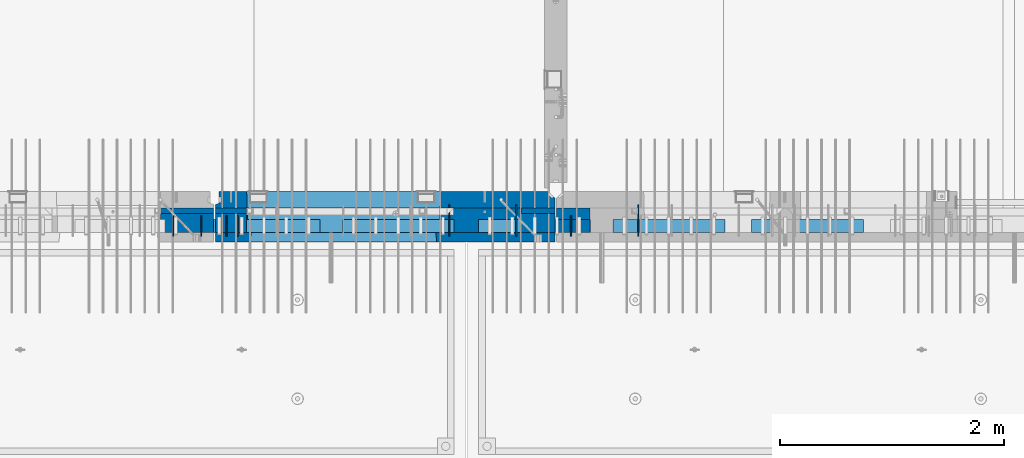
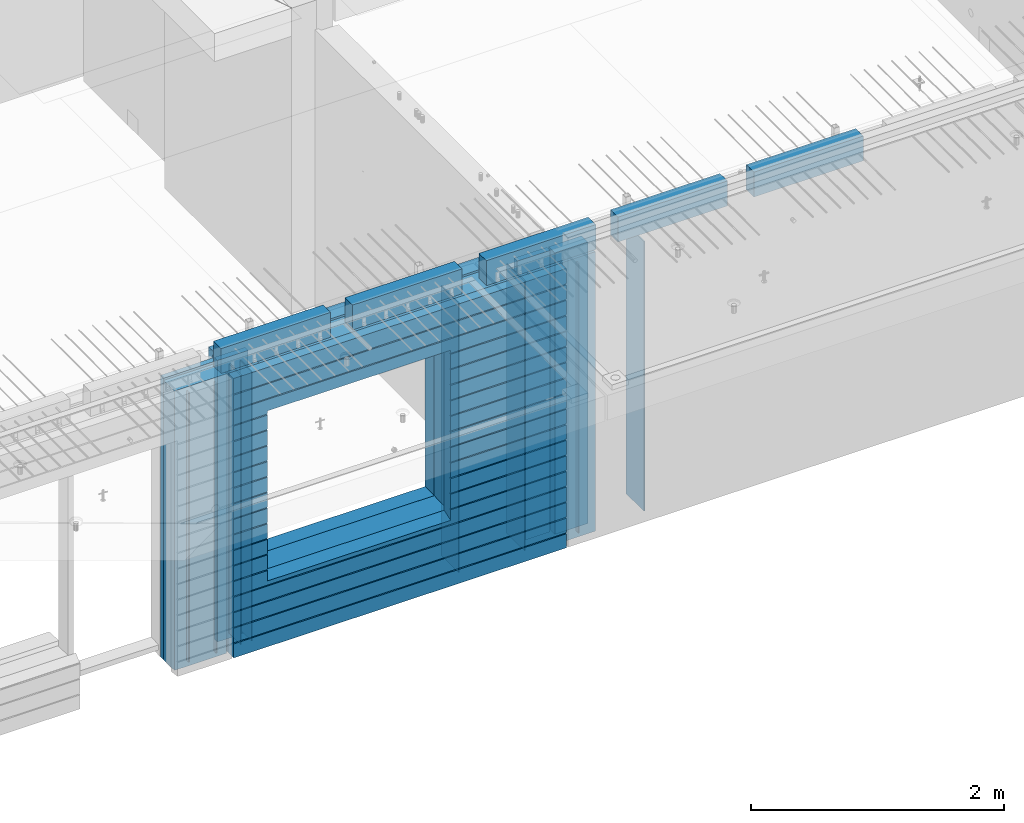
# One storey, part 222 of 334: 24 walls, 10 elements without a shape of their own.
"""IFC2X3 building model written with IfcOpenShell, lengths in millimetres."""

import ifcopenshell
import ifcopenshell.guid

model = None  # the IFC model being written
_history = None  # IfcOwnerHistory: only IFC2X3 demands one
_inside = {}  # id of a spatial element -> (the spatial element, [elements in it])
_under = {}  # id of a project, library or spatial element -> (it, [spatial elements below it])
_declared = {}  # id of a project -> (the project, [libraries it declares])
_typed = {}  # id of a type object -> (the type object, [elements of that type])
_made_of = {}  # id of a material, layer set ... -> (it, [elements and type objects made of it])


def new_model(schema):
    """Start an empty IFC model of exactly this schema.

    Asked for "IFC4X3", IfcOpenShell would pick the latest addendum, in which some entities
    have other attributes; the version numbers below select the first issue.
    IFC2X3 requires an IfcOwnerHistory on every rooted entity: one is made here for all.
    """
    global model, _history
    if schema == "IFC4X3":
        model = ifcopenshell.file(schema_version=(4, 3, 0, 0))
    else:
        model = ifcopenshell.file(schema=schema)
    _inside.clear()
    _under.clear()
    _declared.clear()
    _typed.clear()
    _made_of.clear()
    _history = None
    if model.schema == "IFC2X3":
        org = make("IfcOrganization", Name="unknown")
        user = make(
            "IfcPersonAndOrganization",
            ThePerson=make("IfcPerson", FamilyName="unknown"),
            TheOrganization=org,
        )
        app = make(
            "IfcApplication",
            ApplicationDeveloper=org,
            Version="unknown",
            ApplicationFullName="unknown",
            ApplicationIdentifier="unknown",
        )
        _history = make(
            "IfcOwnerHistory",
            OwningUser=user,
            OwningApplication=app,
            ChangeAction="ADDED",
            CreationDate=0,
        )
    return model


def make(cls, **values):
    """One entity of the class cls with the attributes given. An attribute that is None is left unset."""
    return model.create_entity(
        cls, **{name: value for name, value in values.items() if value is not None}
    )


def rooted(cls, **values):
    """An entity with a GlobalId (a new one), such as an element, a storey or a relation."""
    return make(cls, GlobalId=ifcopenshell.guid.new(), OwnerHistory=_history, **values)


def si_unit(unit_type, name, prefix=None):
    """IfcSIUnit, for example si_unit("LENGTHUNIT", "METRE", prefix="MILLI")."""
    return make("IfcSIUnit", UnitType=unit_type, Prefix=prefix, Name=name)


def assignment(units):
    """IfcUnitAssignment: the units of a project."""
    return None if units is None else make("IfcUnitAssignment", Units=units)


def point(xyz):
    """IfcCartesianPoint."""
    return None if xyz is None else make("IfcCartesianPoint", Coordinates=xyz)


def direction(xyz):
    """IfcDirection."""
    return None if xyz is None else make("IfcDirection", DirectionRatios=xyz)


def frame(location, z_axis=None, x_axis=None):
    """IfcAxis2Placement3D, a coordinate frame: its origin and axes. An axis left out is left unset."""
    return make(
        "IfcAxis2Placement3D",
        Location=point(location),
        Axis=direction(z_axis),
        RefDirection=direction(x_axis),
    )


def origin_with_axes():
    """The frame at (0, 0, 0) with the z axis (0, 0, 1) and the x axis (1, 0, 0) written out."""
    return frame((0.0, 0.0, 0.0), z_axis=(0.0, 0.0, 1.0), x_axis=(1.0, 0.0, 0.0))


def place(relative_to, where):
    """IfcLocalPlacement: puts the frame where relative to a parent placement (None: the world)."""
    return make(
        "IfcLocalPlacement", PlacementRelTo=relative_to, RelativePlacement=where
    )


def context(
    kind, dimensions, precision=None, world=None, true_north=None, identifier=None
):
    """IfcGeometricRepresentationContext, for example the 3D "Model" context."""
    return make(
        "IfcGeometricRepresentationContext",
        ContextIdentifier=identifier,
        ContextType=kind,
        CoordinateSpaceDimension=dimensions,
        Precision=precision,
        WorldCoordinateSystem=world,
        TrueNorth=true_north,
    )


def subcontext(parent, identifier, kind, view, scale=None):
    """IfcGeometricRepresentationSubContext, for example "Body" below "Model"."""
    return make(
        "IfcGeometricRepresentationSubContext",
        ContextIdentifier=identifier,
        ContextType=kind,
        ParentContext=parent,
        TargetScale=scale,
        TargetView=view,
    )


def project(units=None, contexts=None):
    """IfcProject with its units and contexts."""
    return rooted(
        "IfcProject",
        Name="project",
        RepresentationContexts=contexts,
        UnitsInContext=assignment(units),
    )


def spatial(cls, under=None, at=None, **own):
    """A site, building, storey or space (cls), placed at a placement, below another one or the project."""
    s = rooted(cls, ObjectPlacement=at, **own)
    if under is not None:
        _under.setdefault(under.id(), (under, []))[1].append(s)
    return s


def faces_of(points, faces, orient=None, outer=None):
    """IfcFace entities. A face is a list of loops; a loop is a list of indices into points, from 0.

    orient and outer hold one flag for each loop. By default every Orientation is true, the
    first loop of a face is its IfcFaceOuterBound and the others are IfcFaceBound.
    """
    made = []
    for i, loops in enumerate(faces):
        bounds = []
        for j, loop in enumerate(loops):
            is_outer = j == 0 if outer is None else outer[i][j]
            bounds.append(
                make(
                    "IfcFaceOuterBound" if is_outer else "IfcFaceBound",
                    Bound=make("IfcPolyLoop", Polygon=[points[k] for k in loop]),
                    Orientation=True if orient is None else orient[i][j],
                )
            )
        made.append(make("IfcFace", Bounds=bounds))
    return made


def faceted_brep(points, faces, orient=None, outer=None, voids=None):
    """IfcFacetedBrep: a solid bounded by flat faces; with voids (closed shells), ...WithVoids."""
    shared = [point(p) for p in points]
    hull = make("IfcClosedShell", CfsFaces=faces_of(shared, faces, orient, outer))
    if voids is None:
        return make("IfcFacetedBrep", Outer=hull)
    return make(
        "IfcFacetedBrepWithVoids",
        Outer=hull,
        Voids=[
            make(cls, CfsFaces=faces_of(shared, fs, o, b)) for cls, fs, o, b in voids
        ],
    )


def shape(context_of_items, identifier, shape_type, items):
    """IfcShapeRepresentation: the items that make up one representation, for example the "Body"."""
    return make(
        "IfcShapeRepresentation",
        ContextOfItems=context_of_items,
        RepresentationIdentifier=identifier,
        RepresentationType=shape_type,
        Items=items,
    )


def material(Name=None, Category=None):
    """IfcMaterial."""
    return make("IfcMaterial", Name=Name, Category=Category)


def made_of(thing, what):
    """Note that an element or type object is made of a material, layer set ...; save() writes the relation."""
    if what is not None:
        _made_of.setdefault(what.id(), (what, []))[1].append(thing)
    return thing


def type_object(cls, material=None, **own):
    """A type object (cls), such as IfcWallType, which elements share."""
    return made_of(rooted(cls, **own), material)


def element(
    cls,
    number,
    at=None,
    inside=None,
    cuts=None,
    type_object=None,
    material=None,
    context=None,
    identifier="Body",
    shape_type=None,
    held_by="IfcProductDefinitionShape",
    body=None,
    shapes=None,
    **own,
):
    """One element of the class cls, such as IfcWall. Its Tag is "e" and its number.

    at: its placement. inside: the storey or other place that contains it. cuts: it is an
    opening in that element (IfcRelVoidsElement). A single representation is given by context,
    identifier, shape_type and body (its items); several are given by shapes. held_by: the class
    of the entity that holds the representations. save() writes the other relations.
    """
    e = rooted(cls, Tag="e%d" % number, ObjectPlacement=at, **own)
    if body is not None:
        shapes = [shape(context, identifier, shape_type, body)]
    if shapes is not None:
        e.Representation = make(held_by, Representations=shapes)
    if inside is not None:
        _inside.setdefault(inside.id(), (inside, []))[1].append(e)
    if cuts is not None:
        rooted(
            "IfcRelVoidsElement", RelatingBuildingElement=cuts, RelatedOpeningElement=e
        )
    if type_object is not None:
        _typed.setdefault(type_object.id(), (type_object, []))[1].append(e)
    return made_of(e, material)


def aggregate(whole, parts):
    """IfcRelAggregates: a whole, such as a stair, and the parts it consists of."""
    return rooted("IfcRelAggregates", RelatingObject=whole, RelatedObjects=parts)


def save(model, path):
    """Write the relations noted so far, then the file.

    IfcRelAggregates (storeys below a building ...), IfcRelContainedInSpatialStructure (elements
    in a storey), IfcRelDefinesByType, IfcRelAssociatesMaterial and IfcRelDeclares: one each for
    every whole, place, type object, material and project.
    """
    for whole, parts in _under.values():
        aggregate(whole, parts)
    for where, things in _inside.values():
        rooted(
            "IfcRelContainedInSpatialStructure",
            RelatedElements=things,
            RelatingStructure=where,
        )
    for kind, things in _typed.values():
        rooted("IfcRelDefinesByType", RelatedObjects=things, RelatingType=kind)
    for what, things in _made_of.values():
        rooted("IfcRelAssociatesMaterial", RelatedObjects=things, RelatingMaterial=what)
    for by, libraries in _declared.values():
        rooted("IfcRelDeclares", RelatingContext=by, RelatedDefinitions=libraries)
    model.write(path)


model = new_model("IFC2X3")

# Units and contexts
model_context = context("Model", 3, precision=1e-05, world=origin_with_axes())
body_context = subcontext(model_context, "Body", "Model", "MODEL_VIEW")
ifc_project = project(units=[si_unit("LENGTHUNIT", "METRE", prefix="MILLI"), si_unit("AREAUNIT", "SQUARE_METRE"), si_unit("VOLUMEUNIT", "CUBIC_METRE"), si_unit("MASSUNIT", "GRAM", prefix="KILO"), si_unit("TIMEUNIT", "SECOND"), si_unit("PLANEANGLEUNIT", "RADIAN"), si_unit("SOLIDANGLEUNIT", "STERADIAN"), si_unit("THERMODYNAMICTEMPERATUREUNIT", "DEGREE_CELSIUS"), si_unit("LUMINOUSINTENSITYUNIT", "LUMEN")], contexts=[model_context])

# Site, building, storey
site_placement = place(None, origin_with_axes())
site = spatial("IfcSite", under=ifc_project, at=site_placement, CompositionType="ELEMENT")
building_placement = place(site_placement, origin_with_axes())
building = spatial("IfcBuilding", under=site, at=building_placement, CompositionType="ELEMENT")
storey_placement = place(building_placement, origin_with_axes())
storey = spatial("IfcBuildingStorey", under=building, at=storey_placement, Name="3", CompositionType="ELEMENT", Elevation=0.0)

# Assembly, walls
assembly_1_placement = place(storey_placement, origin_with_axes())
assembly_1 = element("IfcElementAssembly", 1, at=assembly_1_placement, inside=storey, AssemblyPlace="NOTDEFINED", PredefinedType="REINFORCEMENT_UNIT")
ifc_material_1 = material(Name="Undefined")
wall_type_1 = type_object("IfcWallType", PredefinedType="NOTDEFINED")
wall_1_placement = place(assembly_1_placement, frame((25665.0, 7780.0, 89115.0), z_axis=(0.0, 0.0, 1.0), x_axis=(0.0, -1.0, 0.0)))
wall_1 = element("IfcWall", 2, at=wall_1_placement, type_object=wall_type_1, material=ifc_material_1, Name="(PD)", context=body_context, shape_type="Brep", body=[
    faceted_brep([(0.0, 5.0, -1300.0), (0.0, 5.0, 1300.0), (180.0, 5.0, 1300.0), (180.0, 5.0, -1300.0), (0.0, -5.0, 1300.0), (180.0, -5.0, 1300.0), (0.0, -5.0, -1300.0), (180.0, -5.0, -1300.0)], [[[0, 1, 2, 3]], [[1, 4, 5, 2]], [[4, 6, 7, 5]], [[6, 0, 3, 7]], [[5, 7, 3, 2]], [[6, 4, 1, 0]]]),
])
wall_2_placement = place(assembly_1_placement, frame((25765.0, 7780.0, 89115.0), z_axis=(0.0, 0.0, 1.0), x_axis=(0.0, -1.0, 0.0)))
wall_2 = element("IfcWall", 3, at=wall_2_placement, type_object=wall_type_1, material=ifc_material_1, Name="(PD)", context=body_context, shape_type="Brep", body=[
    faceted_brep([(0.0, 5.0, -1300.0), (0.0, 5.0, 1300.0), (180.0, 5.0, 1300.0), (180.0, 5.0, -1300.0), (0.0, -5.0, 1300.0), (180.0, -5.0, 1300.0), (0.0, -5.0, -1300.0), (180.0, -5.0, -1300.0)], [[[0, 1, 2, 3]], [[1, 4, 5, 2]], [[4, 6, 7, 5]], [[6, 0, 3, 7]], [[5, 7, 3, 2]], [[6, 4, 1, 0]]]),
])
wall_3_placement = place(assembly_1_placement, frame((28255.0, 7880.0, 89115.0), z_axis=(0.0, 0.0, 1.0), x_axis=(0.0, -1.0, 0.0)))
wall_3 = element("IfcWall", 4, at=wall_3_placement, type_object=wall_type_1, material=ifc_material_1, Name="(PD)", context=body_context, shape_type="Brep", body=[
    faceted_brep([(0.0, 5.0, -1300.0), (0.0, 5.0, 1300.0), (280.0, 5.0, 1300.0), (280.0, 5.0, -1300.0), (0.0, -5.0, 1300.0), (280.0, -5.0, 1300.0), (0.0, -5.0, -1300.0), (280.0, -5.0, -1300.0)], [[[0, 1, 2, 3]], [[1, 4, 5, 2]], [[4, 6, 7, 5]], [[6, 0, 3, 7]], [[5, 7, 3, 2]], [[6, 4, 1, 0]]]),
])

assembly_2_placement = place(storey_placement, origin_with_axes())
assembly_2 = element("IfcElementAssembly", 5, at=assembly_2_placement, inside=storey, AssemblyPlace="NOTDEFINED", PredefinedType="REINFORCEMENT_UNIT")
wall_4_placement = place(assembly_2_placement, frame((28745.0021834468, 7780.0, 89115.0), z_axis=(0.0, 0.0, 1.0), x_axis=(0.0, -1.0, 0.0)))
wall_4 = element("IfcWall", 6, at=wall_4_placement, type_object=wall_type_1, material=ifc_material_1, Name="(PD)", context=body_context, shape_type="Brep", body=[
    faceted_brep([(0.0, 5.0, -1300.0), (0.0, 5.0, 1300.0), (180.0, 5.0, 1300.0), (180.0, 5.0, -1300.0), (0.0, -5.0, 1300.0), (180.0, -5.0, 1300.0), (0.0, -5.0, -1300.0), (180.0, -5.0, -1300.0)], [[[0, 1, 2, 3]], [[1, 4, 5, 2]], [[4, 6, 7, 5]], [[6, 0, 3, 7]], [[5, 7, 3, 2]], [[6, 4, 1, 0]]]),
])
wall_5_placement = place(assembly_2_placement, frame((29345.0021834468, 7880.0, 89115.0), z_axis=(0.0, 0.0, 1.0), x_axis=(0.0, -1.0, 0.0)))
wall_5 = element("IfcWall", 7, at=wall_5_placement, type_object=wall_type_1, material=ifc_material_1, Name="(PD)", context=body_context, shape_type="Brep", body=[
    faceted_brep([(0.0, 5.0, -1300.0), (0.0, 5.0, 1300.0), (280.0, 5.0, 1300.0), (280.0, 5.0, -1300.0), (0.0, -5.0, 1300.0), (280.0, -5.0, 1300.0), (0.0, -5.0, -1300.0), (280.0, -5.0, -1300.0)], [[[0, 1, 2, 3]], [[1, 4, 5, 2]], [[4, 6, 7, 5]], [[6, 0, 3, 7]], [[5, 7, 3, 2]], [[6, 4, 1, 0]]]),
])

# Wall
wall_6_placement = place(assembly_1_placement, frame((27655.0, 7880.0, 89115.0), z_axis=(0.0, 0.0, 1.0), x_axis=(0.0, -1.0, 0.0)))
wall_6 = element("IfcWall", 8, at=wall_6_placement, type_object=wall_type_1, material=ifc_material_1, Name="(PD)", context=body_context, shape_type="Brep", body=[
    faceted_brep([(0.0, 5.0, -1300.0), (0.0, 5.0, 1300.0), (280.0, 5.0, 1300.0), (280.0, 5.0, -1300.0), (0.0, -5.0, 1300.0), (280.0, -5.0, 1300.0), (0.0, -5.0, -1300.0), (280.0, -5.0, -1300.0)], [[[0, 1, 2, 3]], [[1, 4, 5, 2]], [[4, 6, 7, 5]], [[6, 0, 3, 7]], [[5, 7, 3, 2]], [[6, 4, 1, 0]]]),
])

# Assembly, walls
assembly_3_placement = place(storey_placement, origin_with_axes())
assembly_3 = element("IfcElementAssembly", 9, at=assembly_3_placement, inside=storey, AssemblyPlace="NOTDEFINED", PredefinedType="REINFORCEMENT_UNIT")
wall_7_placement = place(assembly_3_placement, frame((25190.0, 7780.0, 89115.0), z_axis=(0.0, 0.0, 1.0), x_axis=(0.0, -1.0, 0.0)))
wall_7 = element("IfcWall", 10, at=wall_7_placement, type_object=wall_type_1, material=ifc_material_1, Name="(PD)", context=body_context, shape_type="Brep", body=[
    faceted_brep([(0.0, 5.0, -1300.0), (0.0, 5.0, 1300.0), (180.0, 5.0, 1300.0), (180.0, 5.0, -1300.0), (0.0, -5.0, 1300.0), (180.0, -5.0, 1300.0), (0.0, -5.0, -1300.0), (180.0, -5.0, -1300.0)], [[[0, 1, 2, 3]], [[1, 4, 5, 2]], [[4, 6, 7, 5]], [[6, 0, 3, 7]], [[5, 7, 3, 2]], [[6, 4, 1, 0]]]),
])
wall_8_placement = place(assembly_3_placement, frame((25440.0, 7780.0, 89115.0), z_axis=(0.0, 0.0, 1.0), x_axis=(0.0, -1.0, 0.0)))
wall_8 = element("IfcWall", 11, at=wall_8_placement, type_object=wall_type_1, material=ifc_material_1, Name="(PD)", context=body_context, shape_type="Brep", body=[
    faceted_brep([(0.0, 5.0, -1300.0), (0.0, 5.0, 1300.0), (180.0, 5.0, 1300.0), (180.0, 5.0, -1300.0), (0.0, -5.0, 1300.0), (180.0, -5.0, 1300.0), (0.0, -5.0, -1300.0), (180.0, -5.0, -1300.0)], [[[0, 1, 2, 3]], [[1, 4, 5, 2]], [[4, 6, 7, 5]], [[6, 0, 3, 7]], [[5, 7, 3, 2]], [[6, 4, 1, 0]]]),
])

# Assemblies, walls
assembly_4_placement = place(storey_placement, origin_with_axes())
assembly_4 = element("IfcElementAssembly", 12, at=assembly_4_placement, inside=storey, AssemblyPlace="NOTDEFINED", PredefinedType="REINFORCEMENT_UNIT")
assembly_5_placement = place(assembly_4_placement, origin_with_axes())
assembly_5 = element("IfcElementAssembly", 13, at=assembly_5_placement, Name="Steel Assembly", AssemblyPlace="NOTDEFINED", PredefinedType="NOTDEFINED")
ifc_material_2 = material()
wall_type_2 = type_object("IfcWallType", PredefinedType="NOTDEFINED")
wall_9_placement = place(assembly_5_placement, frame((26699.9998568133, 7690.00021946163, 90590.0), z_axis=(0.0, 0.0, 1.0), x_axis=(1.0, 0.0, 0.0)))
wall_9 = element("IfcWall", 14, at=wall_9_placement, type_object=wall_type_2, material=ifc_material_2, context=body_context, shape_type="Brep", body=[
    faceted_brep([(0.0, 60.0, -120.0), (0.0, 60.0, 120.0), (1000.0, 60.0, 120.0), (1000.0, 60.0, -120.0), (0.0, -60.0, 120.0), (1000.0, -60.0, 120.0), (0.0, -60.0, -120.0), (1000.0, -60.0, -120.0)], [[[0, 1, 2, 3]], [[1, 4, 5, 2]], [[4, 6, 7, 5]], [[6, 0, 3, 7]], [[5, 7, 3, 2]], [[6, 4, 1, 0]]]),
])
aggregate(assembly_5, [wall_9])
assembly_6_placement = place(assembly_4_placement, origin_with_axes())
assembly_6 = element("IfcElementAssembly", 15, at=assembly_6_placement, Name="Steel Assembly", AssemblyPlace="NOTDEFINED", PredefinedType="NOTDEFINED")
aggregate(assembly_4, [assembly_6, assembly_5])
wall_10_placement = place(assembly_6_placement, frame((25499.9998568133, 7690.00021946163, 90590.0), z_axis=(0.0, 0.0, 1.0), x_axis=(1.0, 0.0, 0.0)))
wall_10 = element("IfcWall", 16, at=wall_10_placement, type_object=wall_type_2, material=ifc_material_2, context=body_context, shape_type="Brep", body=[
    faceted_brep([(0.0, 60.0, -120.0), (0.0, 60.0, 120.0), (1000.0, 60.0, 120.0), (1000.0, 60.0, -120.0), (0.0, -60.0, 120.0), (1000.0, -60.0, 120.0), (0.0, -60.0, -120.0), (1000.0, -60.0, -120.0)], [[[0, 1, 2, 3]], [[1, 4, 5, 2]], [[4, 6, 7, 5]], [[6, 0, 3, 7]], [[5, 7, 3, 2]], [[6, 4, 1, 0]]]),
])
aggregate(assembly_6, [wall_10])

assembly_7_placement = place(storey_placement, origin_with_axes())
assembly_7 = element("IfcElementAssembly", 17, at=assembly_7_placement, inside=storey, AssemblyPlace="NOTDEFINED", PredefinedType="REINFORCEMENT_UNIT")
assembly_8_placement = place(assembly_7_placement, origin_with_axes())
assembly_8 = element("IfcElementAssembly", 18, at=assembly_8_placement, Name="Steel Assembly", AssemblyPlace="NOTDEFINED", PredefinedType="NOTDEFINED")
wall_11_placement = place(assembly_8_placement, frame((30359.9998568133, 7690.00021946163, 90590.0), z_axis=(0.0, 0.0, 1.0), x_axis=(1.0, 0.0, 0.0)))
wall_11 = element("IfcWall", 19, at=wall_11_placement, type_object=wall_type_2, material=ifc_material_2, context=body_context, shape_type="Brep", body=[
    faceted_brep([(0.0, 60.0, -120.0), (0.0, 60.0, 120.0), (1000.0, 60.0, 120.0), (1000.0, 60.0, -120.0), (0.0, -60.0, 120.0), (1000.0, -60.0, 120.0), (0.0, -60.0, -120.0), (1000.0, -60.0, -120.0)], [[[0, 1, 2, 3]], [[1, 4, 5, 2]], [[4, 6, 7, 5]], [[6, 0, 3, 7]], [[5, 7, 3, 2]], [[6, 4, 1, 0]]]),
])
aggregate(assembly_8, [wall_11])
assembly_9_placement = place(assembly_7_placement, origin_with_axes())
assembly_9 = element("IfcElementAssembly", 20, at=assembly_9_placement, Name="Steel Assembly", AssemblyPlace="NOTDEFINED", PredefinedType="NOTDEFINED")
wall_12_placement = place(assembly_9_placement, frame((29119.9998568133, 7690.00021946163, 90590.0), z_axis=(0.0, 0.0, 1.0), x_axis=(1.0, 0.0, 0.0)))
wall_12 = element("IfcWall", 21, at=wall_12_placement, type_object=wall_type_2, material=ifc_material_2, context=body_context, shape_type="Brep", body=[
    faceted_brep([(0.0, 60.0, -120.0), (0.0, 60.0, 120.0), (1000.0, 60.0, 120.0), (1000.0, 60.0, -120.0), (0.0, -60.0, 120.0), (1000.0, -60.0, 120.0), (0.0, -60.0, -120.0), (1000.0, -60.0, -120.0)], [[[0, 1, 2, 3]], [[1, 4, 5, 2]], [[4, 6, 7, 5]], [[6, 0, 3, 7]], [[5, 7, 3, 2]], [[6, 4, 1, 0]]]),
])
aggregate(assembly_9, [wall_12])
assembly_10_placement = place(assembly_7_placement, origin_with_axes())
assembly_10 = element("IfcElementAssembly", 22, at=assembly_10_placement, Name="Steel Assembly", AssemblyPlace="NOTDEFINED", PredefinedType="NOTDEFINED")
aggregate(assembly_7, [assembly_10, assembly_9, assembly_8])
wall_13_placement = place(assembly_10_placement, frame((27919.9998568133, 7690.00021946163, 90590.0), z_axis=(0.0, 0.0, 1.0), x_axis=(1.0, 0.0, 0.0)))
wall_13 = element("IfcWall", 23, at=wall_13_placement, type_object=wall_type_2, material=ifc_material_2, context=body_context, shape_type="Brep", body=[
    faceted_brep([(0.0, 60.0, -120.0), (0.0, 60.0, 120.0), (1000.0, 60.0, 120.0), (1000.0, 60.0, -120.0), (0.0, -60.0, 120.0), (1000.0, -60.0, 120.0), (0.0, -60.0, -120.0), (1000.0, -60.0, -120.0)], [[[0, 1, 2, 3]], [[1, 4, 5, 2]], [[4, 6, 7, 5]], [[6, 0, 3, 7]], [[5, 7, 3, 2]], [[6, 4, 1, 0]]]),
])
aggregate(assembly_10, [wall_13])

# Wall
ifc_material_3 = material(Name="CONCRETE/C35/45")
wall_type_3 = type_object("IfcWallType", PredefinedType="NOTDEFINED")
wall_14_placement = place(assembly_1_placement, frame((28600.0, 7925.0, 89112.5), z_axis=(0.0, 0.0, 1.0), x_axis=(-1.0, 3.00000001838171e-08, 0.0)))
wall_14 = element("IfcWall", 24, at=wall_14_placement, type_object=wall_type_3, material=ifc_material_3, context=body_context, shape_type="Brep", body=[
    faceted_brep([(0.0, 75.0, 1357.5), (0.0, 75.0, -1357.5), (0.0, -15.0, -1357.5), (0.0, -15.0, 1357.5), (60.0, -75.0, -1357.5), (3035.00000000003, 75.0, -1357.5), (3035.00000000003, 45.0, -1357.5), (3002.5, 32.0, -1357.5), (3002.5, -75.0, -1357.5), (60.0, -75.0, 1357.5), (3035.00000000003, 45.0, 1357.5), (3035.00000000003, 75.0, 1357.5), (3002.5, -75.0, 1357.5), (3002.5, 32.0, 1357.5), (2755.00051719707, -75.0, -682.5), (1025.00051719707, -75.0, -682.5), (1025.00051719707, -75.0, 952.5), (2755.00051719707, -75.0, 952.5), (2750.94646314301, 75.0, -678.445945945947), (1029.05457125112, 75.0, -678.445945945947), (1029.05457125112, 75.0, 948.445945945947), (2750.94646314301, 75.0, 948.445945945947)], [[[0, 1, 2, 3]], [[4, 2, 1, 5, 6, 7, 8]], [[3, 2, 4, 9]], [[10, 11, 0, 3, 9, 12, 13]], [[5, 11, 10, 6]], [[13, 7, 6, 10]], [[12, 8, 7, 13]], [[9, 4, 8, 12], [14, 15, 16, 17]], [[14, 18, 19, 15]], [[15, 19, 20, 16]], [[1, 0, 11, 5], [18, 21, 20, 19]], [[16, 20, 21, 17]], [[18, 14, 17, 21]]]),
])

wall_type_4 = type_object("IfcWallType", PredefinedType="NOTDEFINED")
wall_15_placement = place(assembly_2_placement, frame((28915.0000381475, 7800.0, 89112.5), z_axis=(0.0, 0.0, 1.0), x_axis=(-1.0, 3.00000001838171e-08, 0.0)))
wall_15 = element("IfcWall", 25, at=wall_15_placement, type_object=wall_type_4, material=ifc_material_3, context=body_context, shape_type="Brep", body=[
    faceted_brep([(0.0, 50.0, -1357.5), (0.0, 50.0, 1357.5), (300.001908754726, 50.0, 1357.5), (300.001908754726, 50.0, -1357.5), (0.0, -50.0, 1357.5), (300.001908754726, -50.0, 1357.5), (0.0, -50.0, -1357.5), (300.001908754726, -50.0, -1357.5)], [[[0, 1, 2, 3]], [[1, 4, 5, 2]], [[4, 6, 7, 5]], [[6, 0, 3, 7]], [[5, 7, 3, 2]], [[6, 4, 1, 0]]]),
])

ifc_material_4 = material(Name="SPU")
wall_type_5 = type_object("IfcWallType", PredefinedType="NOTDEFINED")
wall_16_placement = place(assembly_2_placement, frame((28915.0000381475, 7690.0, 89102.5), z_axis=(0.0, 0.0, 1.0), x_axis=(-1.0, 3.00000001838171e-08, 0.0)))
wall_16 = element("IfcWall", 26, at=wall_16_placement, type_object=wall_type_5, material=ifc_material_4, context=body_context, shape_type="Brep", body=[
    faceted_brep([(0.0, 60.0, -1347.5), (0.0, 60.0, 1347.5), (300.001908754726, 60.0, 1347.5), (300.001908754726, 60.0, -1347.5), (0.0, -60.0, 1347.5), (300.001908754726, -60.0, 1347.5), (0.0, -60.0, -1347.5), (300.001908754726, -60.0, -1347.5)], [[[0, 1, 2, 3]], [[1, 4, 5, 2]], [[4, 6, 7, 5]], [[6, 0, 3, 7]], [[5, 7, 3, 2]], [[6, 4, 1, 0]]]),
])

aggregate(assembly_2, [wall_16, wall_15, wall_4, wall_5])

wall_type_6 = type_object("IfcWallType", PredefinedType="NOTDEFINED")
wall_17_placement = place(assembly_1_placement, frame((28600.0000381475, 7825.0, 89112.5), z_axis=(0.0, 0.0, 1.0), x_axis=(-1.0, 3.00000001838171e-08, 0.0)))
wall_17 = element("IfcWall", 27, at=wall_17_placement, type_object=wall_type_6, material=ifc_material_3, context=body_context, shape_type="Brep", body=[
    faceted_brep([(0.0, 25.0, -1357.5), (0.0, 25.0, 1357.5), (300.001908754726, 25.0, 1357.5), (300.001908754726, 25.0, -1357.5), (0.0, -25.0, 1357.5), (300.001908754726, -25.0, 1357.5), (0.0, -25.0, -1357.5), (300.001908754726, -25.0, -1357.5)], [[[0, 1, 2, 3]], [[1, 4, 5, 2]], [[4, 6, 7, 5]], [[6, 0, 3, 7]], [[5, 7, 3, 2]], [[6, 4, 1, 0]]]),
])

wall_18_placement = place(assembly_3_placement, frame((25550.0000381475, 7825.00011629906, 89112.5), z_axis=(0.0, 0.0, 1.0), x_axis=(-1.0, 3.00000001838171e-08, 0.0)))
wall_18 = element("IfcWall", 28, at=wall_18_placement, type_object=wall_type_6, material=ifc_material_3, context=body_context, shape_type="Brep", body=[
    faceted_brep([(0.0, 25.0, -1357.5), (0.0, 25.0, 1357.5), (475.001908754726, 25.0, 1357.5), (475.001908754726, 25.0, -1357.5), (0.0, -25.0, 1357.5), (475.001908754726, -25.0, 1357.5), (0.0, -25.0, -1357.5), (475.001908754726, -25.0, -1357.5)], [[[0, 1, 2, 3]], [[1, 4, 5, 2]], [[4, 6, 7, 5]], [[6, 0, 3, 7]], [[5, 7, 3, 2]], [[6, 4, 1, 0]]]),
])

wall_19_placement = place(assembly_1_placement, frame((25845.0000381475, 7825.0, 89112.5), z_axis=(0.0, 0.0, 1.0), x_axis=(-1.0, 3.00000001838171e-08, 0.0)))
wall_19 = element("IfcWall", 29, at=wall_19_placement, type_object=wall_type_6, material=ifc_material_3, context=body_context, shape_type="Brep", body=[
    faceted_brep([(0.0, 25.0, -1357.5), (0.0, 25.0, 1357.5), (280.001908754726, 25.0, 1357.5), (280.001908754726, 25.0, -1357.5), (0.0, -25.0, 1357.5), (280.001908754726, -25.0, 1357.5), (0.0, -25.0, -1357.5), (280.001908754726, -25.0, -1357.5)], [[[0, 1, 2, 3]], [[1, 4, 5, 2]], [[4, 6, 7, 5]], [[6, 0, 3, 7]], [[5, 7, 3, 2]], [[6, 4, 1, 0]]]),
])

wall_type_7 = type_object("IfcWallType", PredefinedType="NOTDEFINED")
wall_20_placement = place(assembly_3_placement, frame((25550.0000381475, 7715.00011629906, 89102.5), z_axis=(0.0, 0.0, 1.0), x_axis=(-1.0, 3.00000001838171e-08, 0.0)))
wall_20 = element("IfcWall", 30, at=wall_20_placement, type_object=wall_type_7, material=ifc_material_4, context=body_context, shape_type="Brep", body=[
    faceted_brep([(0.0, 85.0, -1347.5), (0.0, 85.0, 1347.5), (475.001908754726, 85.0, 1347.5), (475.001908754726, 85.0, -1347.5), (0.0, -85.0, 1347.5), (475.001908754726, -85.0, 1347.5), (0.0, -85.0, -1347.5), (475.001908754726, -85.0, -1347.5)], [[[0, 1, 2, 3]], [[1, 4, 5, 2]], [[4, 6, 7, 5]], [[6, 0, 3, 7]], [[5, 7, 3, 2]], [[6, 4, 1, 0]]]),
])

aggregate(assembly_3, [wall_20, wall_18, wall_7, wall_8])

wall_21_placement = place(assembly_1_placement, frame((28600.0000381475, 7715.0, 89102.5), z_axis=(0.0, 0.0, 1.0), x_axis=(-1.0, 3.00000001838171e-08, 0.0)))
wall_21 = element("IfcWall", 31, at=wall_21_placement, type_object=wall_type_7, material=ifc_material_4, context=body_context, shape_type="Brep", body=[
    faceted_brep([(0.0, 85.0, -1347.5), (0.0, 85.0, 1347.5), (300.001908754726, 85.0, 1347.5), (300.001908754726, 85.0, -1347.5), (0.0, -85.0, 1347.5), (300.001908754726, -85.0, 1347.5), (0.0, -85.0, -1347.5), (300.001908754726, -85.0, -1347.5)], [[[0, 1, 2, 3]], [[1, 4, 5, 2]], [[4, 6, 7, 5]], [[6, 0, 3, 7]], [[5, 7, 3, 2]], [[6, 4, 1, 0]]]),
])

wall_22_placement = place(assembly_1_placement, frame((25845.0000381475, 7715.0, 89102.5), z_axis=(0.0, 0.0, 1.0), x_axis=(-1.0, 3.00000001838171e-08, 0.0)))
wall_22 = element("IfcWall", 32, at=wall_22_placement, type_object=wall_type_7, material=ifc_material_4, context=body_context, shape_type="Brep", body=[
    faceted_brep([(0.0, 85.0, -1347.5), (0.0, 85.0, 1347.5), (280.001908754726, 85.0, 1347.5), (280.001908754726, 85.0, -1347.5), (0.0, -85.0, 1347.5), (280.001908754726, -85.0, 1347.5), (0.0, -85.0, -1347.5), (280.001908754726, -85.0, -1347.5)], [[[0, 1, 2, 3]], [[1, 4, 5, 2]], [[4, 6, 7, 5]], [[6, 0, 3, 7]], [[5, 7, 3, 2]], [[6, 4, 1, 0]]]),
])

ifc_material_5 = material(Name="CONCRETE/C30/37")
wall_type_8 = type_object("IfcWallType", PredefinedType="NOTDEFINED")
wall_23_placement = place(assembly_1_placement, frame((28600.0, 7587.5, 89102.5), z_axis=(0.0, 0.0, 1.0), x_axis=(-1.0, 3.00000001838171e-08, 0.0)))
wall_23 = element("IfcWall", 33, at=wall_23_placement, type_object=wall_type_8, material=ifc_material_5, context=body_context, shape_type="Brep", body=[
    faceted_brep([(3.63797880709171e-12, 32.4999991119639, 1050.00000040043), (3035.0, 32.4999991119785, 1050.00000040044), (3035.0, 32.4999992499725, 1039.99999999921), (3.63797880709171e-12, 32.4999992499725, 1039.99999999921), (0.0, 42.5, 1051.99999988925), (3035.0, 42.5, 1051.99999988925), (0.0, 42.5, 1187.99999994476), (3035.0, 42.5, 1187.99999994476), (-3.63797880709171e-12, 32.499999249967, 1189.99999999923), (3035.0, 32.4999992499634, 1189.99999999921), (-3.63797880709171e-12, 32.4999991119576, 1200.00000040043), (3035.0, 32.4999991119703, 1200.00000040044), (0.0, 42.5, 1201.99999988925), (3035.0, 42.5, 1201.99999988925), (0.0, 42.5, 1347.5), (3035.0, 42.5, 1347.5), (0.0, -42.5, 1347.5), (3035.0, -42.5, 1347.5), (0.0, -42.5, -1347.5), (0.0, 42.5, -1347.5), (3035.0, 42.5, -1347.5), (3035.0, -42.5, -1347.5), (0.0, 42.5, -1212.00000005524), (3035.0, 42.5, -1212.00000005524), (0.0, 32.4999992501671, -1210.00000000079), (3035.0, 32.4999992501644, -1210.0000000008), (0.0, 32.4999991121604, -1199.99999959957), (3035.0, 32.4999991121604, -1199.99999959957), (0.0, 42.5, -1198.00000011075), (3035.0, 42.5, -1198.00000011075), (0.0, 42.5, -1062.00000005522), (3035.0, 42.5, -1062.00000005522), (0.0, 32.4999992506973, -1060.00000000076), (3035.0, 32.4999992506928, -1060.00000000079), (0.0, 32.4999991126861, -1049.99999959956), (3035.0, 32.4999991126924, -1049.99999959956), (0.0, 42.5, -1048.00000011074), (3035.0, 42.5, -1048.00000011074), (0.0, 42.5, -912.000000055254), (3035.0, 42.5, -912.000000055254), (0.0, 32.4999992512376, -910.000000000786), (3035.0, 32.4999992512339, -910.000000000815), (0.0, 32.499999113239, -899.99999959959), (3035.0, 32.4999991132327, -899.99999959959), (0.0, 42.5, -898.000000110769), (3035.0, 42.5, -898.000000110769), (0.0, 42.5, -762.000000055225), (3035.0, 42.5, -762.000000055225), (0.0, 32.4999992517696, -760.000000000757), (3035.0, 32.499999251766, -760.000000000786), (0.0, 32.4999991137702, -749.99999959956), (3035.0, 32.4999991137656, -749.99999959956), (0.0, 42.5, -748.00000011074), (3035.0, 42.5, -748.00000011074), (3035.0, 42.5, 901.999999889245), (3035.0, 32.4999991119894, 900.00000040044), (2723.82404650436, 32.4999991119894, 900.00000040044), (2725.00051719707, 42.5, 901.999999889245), (3035.0, 32.4999992499834, 889.999999999214), (2723.82404652059, 32.4999992499834, 889.999999999214), (3035.0, 42.5, 887.999999944761), (2725.00051719707, 42.5, 887.999999944761), (3035.0, 42.5, 751.999999889245), (2725.00051719707, 42.5, 751.999999889245), (3035.0, 32.4999991119967, 750.000000400425), (2723.82404650436, 32.4999991119967, 750.000000400425), (3035.0, 32.4999992499961, 739.9999999992), (2723.82404652059, 32.4999992499961, 739.9999999992), (3035.0, 42.5, 737.999999944761), (2725.00051719707, 42.5, 737.999999944761), (3035.0, 42.5, 601.99999988926), (2725.00051719707, 42.5, 601.99999988926), (3035.0, 32.4999991120212, 600.000000400454), (2723.82404650436, 32.4999991120212, 600.000000400454), (3035.0, 32.4999992500161, 589.999999999229), (2723.8240465206, 32.4999992500161, 589.999999999229), (3035.0, 42.5, 587.999999944775), (2725.00051719707, 42.5, 587.999999944775), (3035.0, 42.5, 451.999999889231), (2725.00051719707, 42.5, 451.999999889231), (3035.0, 32.4999991120285, 450.000000400425), (2723.82404650436, 32.4999991120285, 450.000000400425), (3035.0, 32.4999992500234, 439.9999999992), (2723.8240465206, 32.4999992500234, 439.9999999992), (3035.0, 42.5, 437.999999944746), (2725.00051719707, 42.5, 437.999999944746), (3035.0, 42.5, 301.999999889245), (2725.00051719707, 42.5, 301.999999889245), (3035.0, 32.4999991120458, 300.00000040044), (2723.82404650437, 32.4999991120458, 300.00000040044), (3035.0, 32.4999992500389, 289.999999999214), (2723.8240465206, 32.4999992500389, 289.999999999214), (3035.0, 42.5, 287.999999944761), (2725.00051719707, 42.5, 287.999999944761), (3035.0, 42.5, 151.99999988926), (2725.00051719707, 42.5, 151.99999988926), (3035.0, 32.4999991120585, 150.000000400454), (2723.82404650437, 32.4999991120585, 150.000000400454), (3035.0, 32.4999992500534, 139.999999999229), (2723.8240465206, 32.4999992500534, 139.999999999229), (3035.0, 42.5, 137.999999944775), (2725.00051719707, 42.5, 137.999999944775), (3035.0, 42.5, 1.99999988924537), (2725.00051719707, 42.5, 1.99999988924537), (3035.0, 32.4999992522926, -610.0000000008), (3035.0, 42.5, -612.000000055239), (2725.00051719707, 42.5, -612.000000055239), (2723.82404652087, 32.4999992522926, -610.0000000008), (3035.0, 32.4999991142904, -599.999999599575), (2723.82404650463, 32.4999991142904, -599.999999599575), (3035.0, 42.5, -598.000000110755), (2725.00051719707, 42.5, -598.000000110755), (3035.0, 42.5, -462.000000055239), (2725.00051719707, 42.5, -462.000000055239), (3035.0, 32.4999992528319, -460.0000000008), (2723.82404652093, 32.4999992528319, -460.0000000008), (3035.0, 32.4999991148297, -449.999999599575), (2723.82404650469, 32.4999991148297, -449.999999599575), (3035.0, 42.5, -448.000000110755), (2725.00051719707, 42.5, -448.000000110755), (3035.0, 42.5, -312.000000055254), (2725.00051719707, 42.5, -312.000000055254), (3035.0, 32.4999992533585, -310.000000000815), (2723.82404652099, 32.4999992533585, -310.000000000815), (3035.0, 32.4999991153563, -299.99999959959), (2723.82404650475, 32.4999991153563, -299.99999959959), (3035.0, 42.5, -298.000000110769), (2725.00051719707, 42.5, -298.000000110769), (3035.0, 42.5, -162.000000055239), (2725.00051719707, 42.499999923677, -162.000000055239), (3035.0, 32.4999992538951, -160.0000000008), (2723.82404652105, 32.4999992538951, -160.0000000008), (3035.0, 32.4999991158938, -149.999999599575), (2723.82404650482, 32.4999991158938, -149.999999599575), (3035.0, 42.5, -148.000000110755), (2725.00051719707, 42.4999999210722, -148.000000110755), (3035.0, 42.5, -12.0000000552391), (2725.00051719707, 42.5, -12.0000000552391), (3035.0, 32.4999992538906, -10.0000000008004), (2723.82404652105, 32.4999992538906, -10.0000000008004), (3035.0, 32.4999991158902, 4.00425051338971e-07), (2723.82404650482, 32.4999991158902, 4.00425051338971e-07), (3035.0, 42.5, 1037.99999994476), (0.0, 42.5, 1037.99999994476), (3.63797880709171e-12, 32.4999992499852, 889.999999999229), (3.63797880709171e-12, 32.4999991119857, 900.000000400425), (1056.17698788978, 32.4999991119894, 900.00000040044), (1056.17698787354, 32.4999992499834, 889.999999999214), (0.0, 42.5, 887.999999944761), (1055.00051719707, 42.5, 887.999999944761), (0.0, 42.5, 751.999999889245), (1055.00051719707, 42.5, 751.999999889245), (0.0, 32.4999991120039, 750.00000040044), (1056.17698788978, 32.4999991119967, 750.000000400425), (0.0, 32.4999992499997, 739.999999999229), (1056.17698787354, 32.4999992499961, 739.9999999992), (0.0, 42.5, 737.999999944761), (1055.00051719707, 42.5, 737.999999944761), (0.0, 42.5, 601.99999988926), (1055.00051719707, 42.5, 601.99999988926), (0.0, 32.4999991120094, 600.00000040044), (1056.17698788977, 32.4999991120212, 600.000000400454), (0.0, 32.499999250017, 589.999999999229), (1056.17698787354, 32.4999992500161, 589.999999999229), (0.0, 42.5, 587.999999944775), (1055.00051719707, 42.5, 587.999999944775), (0.0, 42.5, 451.999999889231), (1055.00051719707, 42.5, 451.999999889231), (0.0, 32.4999991120258, 450.000000400411), (1056.17698788977, 32.4999991120285, 450.000000400425), (0.0, 32.4999992500289, 439.999999999214), (1056.17698787354, 32.4999992500234, 439.9999999992), (0.0, 42.5, 437.999999944746), (1055.00051719707, 42.5, 437.999999944746), (0.0, 42.5, 301.999999889245), (1055.00051719707, 42.5, 301.999999889245), (-3.63797880709171e-12, 32.4999991120458, 300.00000040044), (1056.17698788977, 32.4999991120458, 300.00000040044), (-3.63797880709171e-12, 32.4999992500416, 289.999999999229), (1056.17698787353, 32.4999992500389, 289.999999999214), (0.0, 42.5, 287.999999944761), (1055.00051719707, 42.5, 287.999999944761), (0.0, 42.5, 151.99999988926), (1055.00051719707, 42.5, 151.99999988926), (0.0, 32.4999991120549, 150.00000040044), (1056.17698788977, 32.4999991120585, 150.000000400454), (0.0, 32.4999992500552, 139.999999999229), (1056.17698787353, 32.4999992500534, 139.999999999229), (0.0, 42.5, 137.999999944775), (1055.00051719707, 42.5, 137.999999944775), (0.0, 42.5, 1.99999988924537), (1055.00051719707, 42.5, 1.99999988924537), (0.0, 42.5, -12.0000000552391), (0.0, 42.5, -148.000000110755), (0.0, 32.4999991158993, -149.99999959956), (0.0, 32.4999992538978, -160.000000000757), (0.0, 42.5, -162.000000055239), (0.0, 42.5, -298.000000110769), (0.0, 32.4999991153618, -299.99999959959), (0.0, 32.4999992533649, -310.000000000786), (0.0, 42.5, -312.000000055254), (0.0, 42.5, -448.000000110755), (0.0, 32.4999991148252, -449.999999599575), (0.0, 32.4999992528365, -460.000000000771), (0.0, 42.5, -462.000000055239), (0.0, 42.5, -598.000000110755), (0.0, 32.4999991143004, -599.99999959956), (0.0, 32.4999992522971, -610.000000000771), (0.0, 42.5, -612.000000055239), (0.0, 42.5, 901.999999889245), (0.0, 32.4999991158911, 4.00425051338971e-07), (0.0, 32.4999992538942, -10.0000000007858), (1056.17698788932, 32.4999991158902, 4.00425051338971e-07), (1056.17698787308, 32.4999992538906, -10.0000000008004), (1055.00051719707, 42.5, -12.0000000552391), (1055.00051719707, 42.4999994958771, -148.000000110755), (1056.17698788932, 32.4999991158938, -149.999999599575), (1056.17698787308, 32.4999992538951, -160.0000000008), (1055.00051719707, 42.499999512519, -162.000000055239), (1055.00051719707, 42.5, -298.000000110769), (1056.17698788938, 32.4999991153563, -299.99999959959), (1056.17698787315, 32.4999992533585, -310.000000000815), (1055.00051719707, 42.5, -312.000000055254), (1055.00051719707, 42.5, -448.000000110755), (1056.17698788944, 32.4999991148297, -449.999999599575), (1056.17698787321, 32.4999992528319, -460.0000000008), (1055.00051719707, 42.5, -462.000000055239), (1055.00051719707, 42.5, -598.000000110755), (1056.1769878895, 32.4999991142904, -599.999999599575), (1056.17698787327, 32.4999992522926, -610.0000000008), (1055.00051719707, 42.5, -612.000000055239), (2725.00051719707, 42.5, -712.5), (1055.00051719707, 42.5, -712.5), (2715.00051719707, -42.5, 927.5), (2715.00051719707, -42.5, 932.5), (2725.00051719707, 42.5, 927.5), (2715.00051719707, -42.5, -662.5), (1065.00051719707, -42.5, -662.5), (1065.00051719707, -42.5, 927.5), (1065.00051719707, -42.5, 932.5), (1065.00051719707, 42.5, 927.5), (2715.00051719707, 42.5, 927.5), (1055.00051719707, 42.5, 927.5), (1055.00051719707, 42.5, 901.999999889245)], [[[0, 1, 2, 3]], [[4, 5, 1, 0]], [[5, 4, 6, 7]], [[8, 9, 7, 6]], [[10, 11, 9, 8]], [[12, 13, 11, 10]], [[14, 15, 13, 12]], [[14, 16, 17, 15]], [[18, 19, 20, 21]], [[20, 19, 22, 23]], [[24, 25, 23, 22]], [[26, 27, 25, 24]], [[28, 29, 27, 26]], [[29, 28, 30, 31]], [[32, 33, 31, 30]], [[34, 35, 33, 32]], [[36, 37, 35, 34]], [[37, 36, 38, 39]], [[40, 41, 39, 38]], [[42, 43, 41, 40]], [[44, 45, 43, 42]], [[45, 44, 46, 47]], [[48, 49, 47, 46]], [[50, 51, 49, 48]], [[52, 53, 51, 50]], [[54, 55, 56, 57]], [[55, 58, 59, 56]], [[58, 60, 61, 59]], [[60, 62, 63, 61]], [[62, 64, 65, 63]], [[64, 66, 67, 65]], [[66, 68, 69, 67]], [[68, 70, 71, 69]], [[70, 72, 73, 71]], [[72, 74, 75, 73]], [[74, 76, 77, 75]], [[76, 78, 79, 77]], [[78, 80, 81, 79]], [[80, 82, 83, 81]], [[82, 84, 85, 83]], [[84, 86, 87, 85]], [[86, 88, 89, 87]], [[88, 90, 91, 89]], [[90, 92, 93, 91]], [[92, 94, 95, 93]], [[94, 96, 97, 95]], [[96, 98, 99, 97]], [[98, 100, 101, 99]], [[100, 102, 103, 101]], [[104, 105, 106, 107]], [[108, 104, 107, 109]], [[110, 108, 109, 111]], [[112, 110, 111, 113]], [[114, 112, 113, 115]], [[116, 114, 115, 117]], [[118, 116, 117, 119]], [[120, 118, 119, 121]], [[122, 120, 121, 123]], [[124, 122, 123, 125]], [[126, 124, 125, 127]], [[128, 126, 127, 129]], [[130, 128, 129, 131]], [[132, 130, 131, 133]], [[134, 132, 133, 135]], [[136, 134, 135, 137]], [[138, 136, 137, 139]], [[140, 138, 139, 141]], [[102, 140, 141, 103]], [[100, 98, 96, 94, 92, 90, 88, 86, 84, 82, 80, 78, 76, 74, 72, 70, 68, 66, 64, 62, 60, 58, 55, 54, 142, 2, 1, 5, 7, 9, 11, 13, 15, 17, 21, 20, 23, 25, 27, 29, 31, 33, 35, 37, 39, 41, 43, 45, 47, 49, 51, 53, 105, 104, 108, 110, 112, 114, 116, 118, 120, 122, 124, 126, 128, 130, 132, 134, 136, 138, 140, 102]], [[3, 2, 142, 143]], [[144, 145, 146, 147]], [[148, 144, 147, 149]], [[150, 148, 149, 151]], [[152, 150, 151, 153]], [[154, 152, 153, 155]], [[156, 154, 155, 157]], [[158, 156, 157, 159]], [[160, 158, 159, 161]], [[162, 160, 161, 163]], [[164, 162, 163, 165]], [[166, 164, 165, 167]], [[168, 166, 167, 169]], [[170, 168, 169, 171]], [[172, 170, 171, 173]], [[174, 172, 173, 175]], [[176, 174, 175, 177]], [[178, 176, 177, 179]], [[180, 178, 179, 181]], [[182, 180, 181, 183]], [[184, 182, 183, 185]], [[186, 184, 185, 187]], [[188, 186, 187, 189]], [[190, 188, 189, 191]], [[192, 193, 194, 195, 196, 197, 198, 199, 200, 201, 202, 203, 204, 205, 206, 207, 208, 52, 50, 48, 46, 44, 42, 40, 38, 36, 34, 32, 30, 28, 26, 24, 22, 19, 18, 16, 14, 12, 10, 8, 6, 4, 0, 3, 143, 209, 145, 144, 148, 150, 152, 154, 156, 158, 160, 162, 164, 166, 168, 170, 172, 174, 176, 178, 180, 182, 184, 186, 188, 190, 210, 211]], [[211, 210, 212, 213]], [[192, 211, 213, 214]], [[193, 192, 214, 215]], [[194, 193, 215, 216]], [[195, 194, 216, 217]], [[196, 195, 217, 218]], [[197, 196, 218, 219]], [[198, 197, 219, 220]], [[199, 198, 220, 221]], [[200, 199, 221, 222]], [[201, 200, 222, 223]], [[202, 201, 223, 224]], [[203, 202, 224, 225]], [[204, 203, 225, 226]], [[205, 204, 226, 227]], [[206, 205, 227, 228]], [[207, 206, 228, 229]], [[208, 207, 229, 230]], [[231, 106, 105, 53, 52, 208, 230, 232]], [[233, 234, 235, 57, 56, 59, 61, 63, 65, 67, 69, 71, 73, 75, 77, 79, 81, 83, 85, 87, 89, 91, 93, 95, 97, 99, 101, 103, 141, 139, 137, 135, 133, 131, 129, 127, 125, 123, 121, 119, 117, 115, 113, 111, 109, 107, 106, 231, 236]], [[232, 237, 236, 231]], [[16, 18, 21, 17], [233, 236, 237, 238, 239, 234]], [[240, 241, 235, 234, 239, 242]], [[209, 143, 142, 54, 57, 235, 241, 240, 242, 243]], [[145, 209, 243, 146]], [[242, 239, 238, 237, 232, 230, 229, 228, 227, 226, 225, 224, 223, 222, 221, 220, 219, 218, 217, 216, 215, 214, 213, 212, 191, 189, 187, 185, 183, 181, 179, 177, 175, 173, 171, 169, 167, 165, 163, 161, 159, 157, 155, 153, 151, 149, 147, 146, 243]], [[210, 190, 191, 212]]]),
])

ifc_material_6 = material(Name="COS5gt")
wall_type_9 = type_object("IfcWallType", PredefinedType="NOTDEFINED")
wall_24_placement = place(assembly_1_placement, frame((28600.0, 7740.0, 89102.5), z_axis=(0.0, 0.0, 1.0), x_axis=(-1.0, 3.00000001838171e-08, 0.0)))
wall_24 = element("IfcWall", 34, at=wall_24_placement, type_object=wall_type_9, material=ifc_material_6, context=body_context, shape_type="Brep", body=[
    faceted_brep([(2755.0, 90.0, -1347.5), (2755.0, -110.0, -1347.5), (300.001870607201, -110.0, -1347.5), (300.001870607201, 90.0, -1347.5), (2755.0, 90.0, -1297.5), (300.001870607201, 90.0, -1297.5), (2755.0, 110.0, -1297.5), (300.001870607201, 110.0, -1297.5), (2755.0, 110.0, 1347.5), (2755.0, -110.0, 1347.5), (2750.94646314301, -110.0, -668.445945945947), (2745.00051719707, 110.0, -662.5), (2715.00051719707, 110.0, -662.5), (1065.00051719707, 110.0, -662.5), (1035.00051719707, 110.0, -662.5), (1029.05457125112, -110.0, -668.445945945947), (300.001870607201, -110.0, 1347.5), (1029.05457125112, -110.0, 958.445945945947), (2750.94646314301, -110.0, 958.445945945947), (2745.00051719707, 110.0, -657.5), (2745.00051719707, 110.0, 952.5), (1035.00051719707, 110.0, 952.5), (1035.00051719707, 110.0, -657.5), (300.001870607201, 110.0, 1347.5)], [[[0, 1, 2, 3]], [[4, 0, 3, 5]], [[6, 4, 5, 7]], [[8, 9, 1, 0, 4, 6]], [[10, 11, 12, 13, 14, 15]], [[1, 9, 16, 2], [10, 15, 17, 18]], [[19, 11, 10, 18, 20]], [[17, 21, 20, 18]], [[15, 14, 22, 21, 17]], [[8, 6, 7, 23], [14, 13, 12, 11, 19, 20, 21, 22]], [[9, 8, 23, 16]], [[7, 5, 3, 2, 16, 23]]]),
])

aggregate(assembly_1, [wall_21, wall_17, wall_22, wall_1, wall_2, wall_3, wall_19, wall_6, wall_23, wall_24, wall_14])

save(model, "model.ifc")
